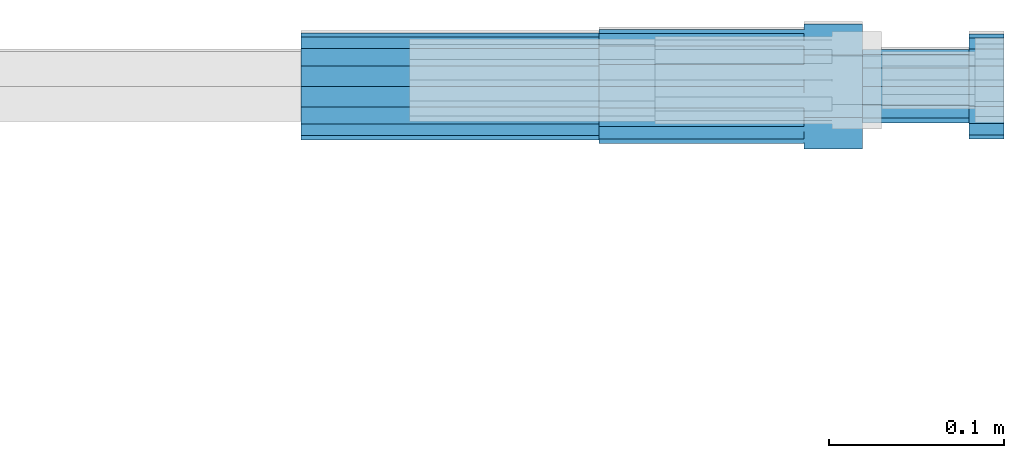
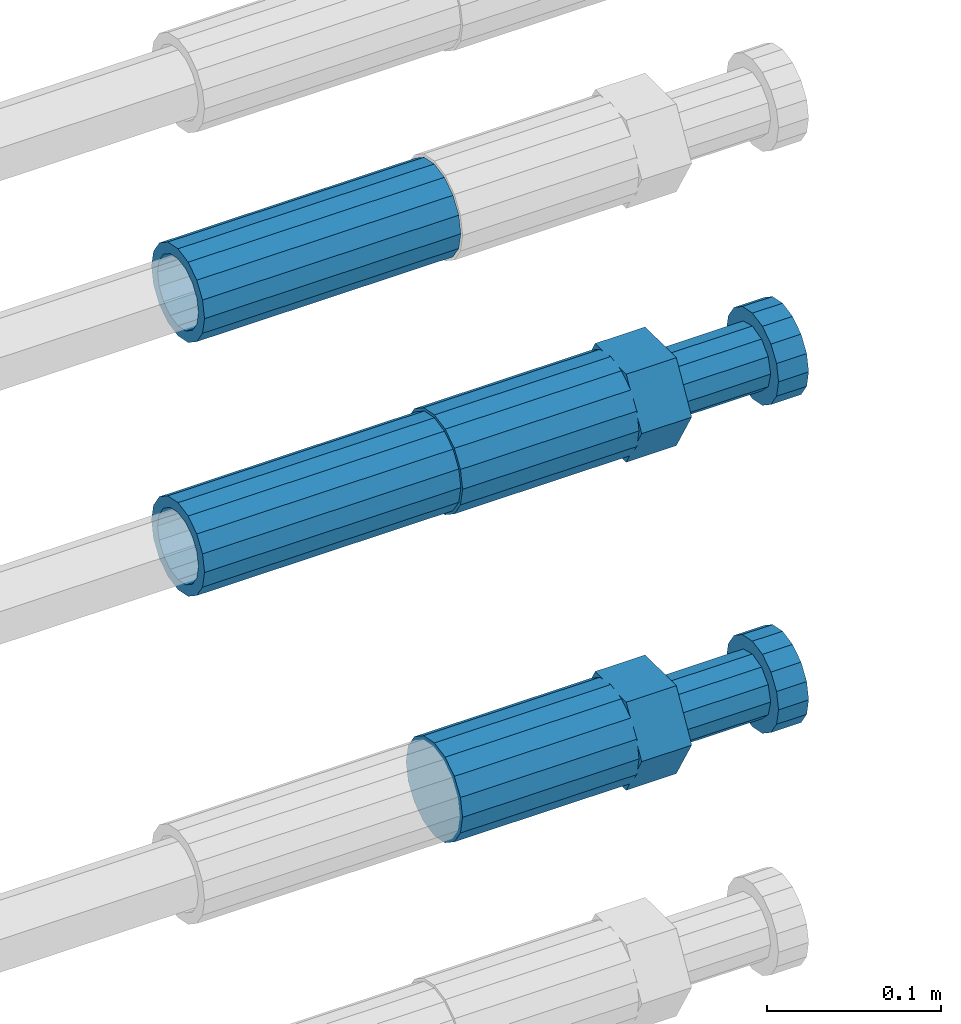
# One storey, part 117 of 119: 4 beams.
"""IFC2X3 building model written with IfcOpenShell, lengths in millimetres."""

from ifc_helpers import new_model, si_unit, frame, origin_with_axes, place, context, subcontext, project, spatial, faceted_brep, material, type_object, element, save


model = new_model("IFC2X3")

# Units and contexts
model_context = context("Model", 3, precision=1e-05, world=origin_with_axes())
body_context = subcontext(model_context, "Body", "Model", "MODEL_VIEW")
ifc_project = project(units=[si_unit("LENGTHUNIT", "METRE", prefix="MILLI"), si_unit("AREAUNIT", "SQUARE_METRE"), si_unit("VOLUMEUNIT", "CUBIC_METRE"), si_unit("MASSUNIT", "GRAM", prefix="KILO"), si_unit("TIMEUNIT", "SECOND"), si_unit("PLANEANGLEUNIT", "RADIAN"), si_unit("SOLIDANGLEUNIT", "STERADIAN"), si_unit("THERMODYNAMICTEMPERATUREUNIT", "DEGREE_CELSIUS"), si_unit("LUMINOUSINTENSITYUNIT", "LUMEN")], contexts=[model_context])

# Site, building, storey
site_placement = place(None, origin_with_axes())
site = spatial("IfcSite", under=ifc_project, at=site_placement, CompositionType="ELEMENT")
building_placement = place(site_placement, origin_with_axes())
building = spatial("IfcBuilding", under=site, at=building_placement, Name="Undefined", CompositionType="ELEMENT")
storey_placement = place(building_placement, origin_with_axes())
storey = spatial("IfcBuildingStorey", under=building, at=storey_placement, Name="Undefined", CompositionType="ELEMENT", Elevation=0.0)

# Beams
ifc_material = material(Name="STEEL/S275")
beam_type_1 = type_object("IfcBeamType", PredefinedType="NOTDEFINED")
beam_1_placement = place(storey_placement, frame((2039349.03023304, 6206399.98994599, 22034.9894122711), z_axis=(0.0, 0.0, 1.0), x_axis=(1.0, 0.0, 0.0)))
element("IfcBeam", 1, at=beam_1_placement, inside=storey, type_object=beam_type_1, material=ifc_material, Name="AG40N", context=body_context, shape_type="Brep", body=[
    faceted_brep([(1.62981450557709e-09, -23.4999999990687, 0.0), (7.45058059692383e-09, -21.7111690142192, 8.99306066057534), (170.000002125278, -21.711168999318, 8.99306066022245), (170.000002127141, -23.4999999844003, -3.66071617463604e-10), (4.65661287307739e-09, -16.6170093587134, 16.6170093578889), (170.000002122484, -16.6170093440451, 16.6170093575288), (1.86264514923096e-09, -8.99306066217832, 21.7111690140277), (170.000002118759, -8.99306064750999, 21.7111690136603), (2.3283064365387e-10, 9.31322574615479e-10, 23.5), (170.000002114102, 1.28056854009628e-08, 23.4999999996485), (-6.51925802230835e-09, 8.99306065868586, 21.7111690140241), (170.00000211224, 8.99306067335419, 21.7111690136639), (-7.45058059692383e-09, 16.6170093561523, 16.6170093578853), (170.000002109446, 16.6170093708206, 16.6170093575324), (-9.31322574615479e-09, 21.711169013055, 8.99306066057534), (170.000002108514, 21.7111690277234, 8.99306066022245), (-1.16415321826935e-09, 23.5000000009313, 0.0), (170.000002108514, 23.5000000144355, -3.66071617463604e-10), (-8.38190317153931e-09, 21.7111690151505, -8.99306066059444), (170.000002110377, 21.7111690300517, -8.9930606609546), (-5.58793544769287e-09, 16.6170093598776, -16.6170093579008), (170.000002113171, 16.6170093745459, -16.6170093582609), (-9.31322574615479e-10, 8.99306066334248, -21.7111690140396), (170.000002115965, 8.99306067801081, -21.7111690143961), (2.3283064365387e-10, 9.31322574615479e-10, -23.5), (170.00000211969, 1.7927959561348e-08, -23.5000000003843), (5.58793544769287e-09, -8.99306065752171, -21.7111690140396), (170.000002123415, -8.99306064285338, -21.7111690143961), (8.38190317153931e-09, -16.6170093549881, -16.6170093579008), (170.000002125278, -16.6170093403198, -16.6170093582646), (9.31322574615479e-09, -21.7111690121237, -8.99306066059444), (170.000002127141, -21.7111689972226, -8.9930606609546), (1.11758708953857e-08, -30.4999999990687, -9.54969436861575e-12), (1.30385160446167e-08, -28.1783257392235, -11.6718446871514), (170.000002129003, -28.1783257243223, -11.6718446875116), (170.000002129935, -30.4999999841675, -3.66071617463604e-10), (1.02445483207703e-08, -21.5667568228673, -21.5667568262129), (170.000002128072, -21.566756808199, -21.5667568265694), (7.45058059692383e-09, -11.6718446831219, -28.1783257416196), (170.000002125278, -11.6718446684536, -28.1783257419834), (3.72529029846191e-09, 3.95812094211578e-09, -30.5000000000277), (170.00000211969, 1.83936208486557e-08, -30.5000000003879), (-9.31322574615479e-10, 11.6718446905725, -28.1783257416232), (170.000002115965, 11.6718447052408, -28.1783257419797), (-6.51925802230835e-09, 21.5667568286881, -21.5667568262093), (170.000002110377, 21.5667568433564, -21.5667568265694), (-9.31322574615479e-09, 28.178325742716, -11.6718446871478), (170.000002108514, 28.1783257573843, -11.6718446875079), (-1.21071934700012e-08, 30.5, -5.91171556152403e-12), (170.000002106652, 30.5000000144355, -3.62433638656512e-10), (-1.21071934700012e-08, 28.1783257401548, 11.6718446871359), (170.00000210572, 28.1783257548232, 11.6718446867794), (-1.02445483207703e-08, 21.5667568240315, 21.5667568261974), (170.000002107583, 21.566756838467, 21.5667568258409), (-7.45058059692383e-09, 11.671844684286, 28.1783257416041), (170.000002110377, 11.6718446989544, 28.178325741244), (-2.79396772384644e-09, -2.56113708019257e-09, 30.5000000000159), (170.000002114102, 1.18743628263474e-08, 30.4999999996558), (1.86264514923096e-09, -11.6718446896411, 28.1783257416114), (170.000002118759, -11.67184467474, 28.178325741244), (7.45058059692383e-09, -21.5667568275239, 21.5667568261974), (170.000002123415, -21.5667568126228, 21.5667568258373), (1.02445483207703e-08, -28.1783257415518, 11.6718446871359), (170.000002127141, -28.1783257271163, 11.6718446867794)], [[[0, 1, 2, 3]], [[1, 4, 5, 2]], [[4, 6, 7, 5]], [[6, 8, 9, 7]], [[8, 10, 11, 9]], [[10, 12, 13, 11]], [[12, 14, 15, 13]], [[14, 16, 17, 15]], [[16, 18, 19, 17]], [[18, 20, 21, 19]], [[20, 22, 23, 21]], [[22, 24, 25, 23]], [[24, 26, 27, 25]], [[26, 28, 29, 27]], [[28, 30, 31, 29]], [[30, 0, 3, 31]], [[32, 33, 34, 35]], [[33, 36, 37, 34]], [[36, 38, 39, 37]], [[38, 40, 41, 39]], [[40, 42, 43, 41]], [[42, 44, 45, 43]], [[44, 46, 47, 45]], [[46, 48, 49, 47]], [[48, 50, 51, 49]], [[50, 52, 53, 51]], [[52, 54, 55, 53]], [[54, 56, 57, 55]], [[56, 58, 59, 57]], [[58, 60, 61, 59]], [[60, 62, 63, 61]], [[62, 32, 35, 63]], [[37, 39, 41, 43, 45, 47, 49, 51, 53, 55, 57, 59, 61, 63, 35, 34], [5, 7, 9, 11, 13, 15, 17, 19, 21, 23, 25, 27, 29, 31, 3, 2]], [[62, 60, 58, 56, 54, 52, 50, 48, 46, 44, 42, 40, 38, 36, 33, 32], [30, 28, 26, 24, 22, 20, 18, 16, 14, 12, 10, 8, 6, 4, 1, 0]]]),
])
beam_2_placement = place(storey_placement, frame((2039349.03023304, 6206399.98994599, 22212.9894122711), z_axis=(0.0, 0.0, 1.0), x_axis=(1.0, 0.0, 0.0)))
element("IfcBeam", 2, at=beam_2_placement, inside=storey, type_object=beam_type_1, material=ifc_material, Name="AG40N", context=body_context, shape_type="Brep", body=[
    faceted_brep([(1.62981450557709e-09, -23.4999999990687, 0.0), (7.45058059692383e-09, -21.7111690142192, 8.99306066057534), (170.000002125278, -21.711168999318, 8.99306066022245), (170.000002127141, -23.4999999844003, -3.66071617463604e-10), (4.65661287307739e-09, -16.6170093587134, 16.6170093578889), (170.000002122484, -16.6170093440451, 16.6170093575288), (1.86264514923096e-09, -8.99306066217832, 21.7111690140277), (170.000002118759, -8.99306064750999, 21.7111690136603), (2.3283064365387e-10, 9.31322574615479e-10, 23.5), (170.000002114102, 1.28056854009628e-08, 23.4999999996485), (-6.51925802230835e-09, 8.99306065868586, 21.7111690140241), (170.00000211224, 8.99306067335419, 21.7111690136639), (-7.45058059692383e-09, 16.6170093561523, 16.6170093578853), (170.000002109446, 16.6170093708206, 16.6170093575324), (-9.31322574615479e-09, 21.711169013055, 8.99306066057534), (170.000002108514, 21.7111690277234, 8.99306066022245), (-1.16415321826935e-09, 23.5000000009313, 0.0), (170.000002108514, 23.5000000144355, -3.66071617463604e-10), (-8.38190317153931e-09, 21.7111690151505, -8.99306066059444), (170.000002110377, 21.7111690300517, -8.9930606609546), (-5.58793544769287e-09, 16.6170093598776, -16.6170093579008), (170.000002113171, 16.6170093745459, -16.6170093582609), (-9.31322574615479e-10, 8.99306066334248, -21.7111690140396), (170.000002115965, 8.99306067801081, -21.7111690143961), (2.3283064365387e-10, 9.31322574615479e-10, -23.5), (170.00000211969, 1.7927959561348e-08, -23.5000000003843), (5.58793544769287e-09, -8.99306065752171, -21.7111690140396), (170.000002123415, -8.99306064285338, -21.7111690143961), (8.38190317153931e-09, -16.6170093549881, -16.6170093579008), (170.000002125278, -16.6170093403198, -16.6170093582646), (9.31322574615479e-09, -21.7111690121237, -8.99306066059444), (170.000002127141, -21.7111689972226, -8.9930606609546), (1.11758708953857e-08, -30.4999999990687, -9.54969436861575e-12), (1.30385160446167e-08, -28.1783257392235, -11.6718446871514), (170.000002129003, -28.1783257243223, -11.6718446875116), (170.000002129935, -30.4999999841675, -3.66071617463604e-10), (1.02445483207703e-08, -21.5667568228673, -21.5667568262129), (170.000002128072, -21.566756808199, -21.5667568265694), (7.45058059692383e-09, -11.6718446831219, -28.1783257416196), (170.000002125278, -11.6718446684536, -28.1783257419834), (3.72529029846191e-09, 3.95812094211578e-09, -30.5000000000277), (170.00000211969, 1.83936208486557e-08, -30.5000000003879), (-9.31322574615479e-10, 11.6718446905725, -28.1783257416232), (170.000002115965, 11.6718447052408, -28.1783257419797), (-6.51925802230835e-09, 21.5667568286881, -21.5667568262093), (170.000002110377, 21.5667568433564, -21.5667568265694), (-9.31322574615479e-09, 28.178325742716, -11.6718446871478), (170.000002108514, 28.1783257573843, -11.6718446875079), (-1.21071934700012e-08, 30.5, -5.91171556152403e-12), (170.000002106652, 30.5000000144355, -3.62433638656512e-10), (-1.21071934700012e-08, 28.1783257401548, 11.6718446871359), (170.00000210572, 28.1783257548232, 11.6718446867794), (-1.02445483207703e-08, 21.5667568240315, 21.5667568261974), (170.000002107583, 21.566756838467, 21.5667568258409), (-7.45058059692383e-09, 11.671844684286, 28.1783257416041), (170.000002110377, 11.6718446989544, 28.178325741244), (-2.79396772384644e-09, -2.56113708019257e-09, 30.5000000000159), (170.000002114102, 1.18743628263474e-08, 30.4999999996558), (1.86264514923096e-09, -11.6718446896411, 28.1783257416114), (170.000002118759, -11.67184467474, 28.178325741244), (7.45058059692383e-09, -21.5667568275239, 21.5667568261974), (170.000002123415, -21.5667568126228, 21.5667568258373), (1.02445483207703e-08, -28.1783257415518, 11.6718446871359), (170.000002127141, -28.1783257271163, 11.6718446867794)], [[[0, 1, 2, 3]], [[1, 4, 5, 2]], [[4, 6, 7, 5]], [[6, 8, 9, 7]], [[8, 10, 11, 9]], [[10, 12, 13, 11]], [[12, 14, 15, 13]], [[14, 16, 17, 15]], [[16, 18, 19, 17]], [[18, 20, 21, 19]], [[20, 22, 23, 21]], [[22, 24, 25, 23]], [[24, 26, 27, 25]], [[26, 28, 29, 27]], [[28, 30, 31, 29]], [[30, 0, 3, 31]], [[32, 33, 34, 35]], [[33, 36, 37, 34]], [[36, 38, 39, 37]], [[38, 40, 41, 39]], [[40, 42, 43, 41]], [[42, 44, 45, 43]], [[44, 46, 47, 45]], [[46, 48, 49, 47]], [[48, 50, 51, 49]], [[50, 52, 53, 51]], [[52, 54, 55, 53]], [[54, 56, 57, 55]], [[56, 58, 59, 57]], [[58, 60, 61, 59]], [[60, 62, 63, 61]], [[62, 32, 35, 63]], [[37, 39, 41, 43, 45, 47, 49, 51, 53, 55, 57, 59, 61, 63, 35, 34], [5, 7, 9, 11, 13, 15, 17, 19, 21, 23, 25, 27, 29, 31, 3, 2]], [[62, 60, 58, 56, 54, 52, 50, 48, 46, 44, 42, 40, 38, 36, 33, 32], [30, 28, 26, 24, 22, 20, 18, 16, 14, 12, 10, 8, 6, 4, 1, 0]]]),
])
beam_type_2 = type_object("IfcBeamType", Name="ROD65", PredefinedType="NOTDEFINED")
beam_3_placement = place(storey_placement, frame((2039519.03023304, 6206399.98994599, 21804.9894143674), z_axis=(0.0, 0.0, 1.0), x_axis=(1.0, 0.0, 0.0)))
element("IfcBeam", 3, at=beam_3_placement, inside=storey, type_object=beam_type_2, material=ifc_material, Name="AGB40", ObjectType="ROD65", context=body_context, shape_type="Brep", body=[
    faceted_brep([(116.999999999069, 17.8249999252148, 30.8738056446964), (116.999999998137, 22.0056957420893, 23.632628078838), (116.999999999069, 12.4372115600854, 30.0260848066173), (116.999999999069, 8.17543111252598, 30.8738056446964), (117.000000000931, -17.8250000746921, 30.8738056446964), (150.200000001118, -17.8250000723638, 30.8738056446964), (150.199999999255, 17.8249999275431, 30.8738056446964), (117.000000000931, -8.17543109622784, 30.8738056446964), (117.000000001863, -22.0056959956419, 23.6326278985034), (117.000000000931, -12.4372115437873, 30.0260848066173), (117.000000001863, -35.6500000746455, -2.18278728425503e-10), (150.200000002049, -35.6500000723172, -2.18278728425503e-10), (117.000000001863, -30.8443149488885, 8.32369080289209), (117.000000001863, -30.8443149488885, -8.32369080355784), (117.000000002794, -32.4999999918509, 0.0), (117.000000000931, -17.8250000746921, -30.873805645133), (150.200000001118, -17.8250000723638, -30.873805645133), (117.000000001863, -22.0056959961075, -23.6326278982269), (117.000000000931, -8.17543109389953, -30.873805645133), (117.000000000931, -12.4372115437873, -30.0260848066173), (116.999999999069, 17.8249999252148, -30.873805645133), (150.199999999255, 17.8249999275431, -30.873805645133), (116.999999999069, 8.17543111019768, -30.873805645133), (116.999999999069, 12.4372115600854, -30.0260848066173), (116.999999998137, 22.005695742555, -23.6326280785652), (116.999999998137, 35.6499999251682, -2.18278728425503e-10), (150.199999998324, 35.6499999277294, -2.18278728425503e-10), (116.999999998137, 30.8443150522653, -8.32369036550881), (116.999999997206, 32.5000000081491, 0.0), (116.999999998137, 30.8443150522653, 8.32369036483942), (1.86264514923096e-09, -22.9809703885112, 22.9809703885621), (1.86264514923096e-09, -30.0260848065373, 12.4372115518672), (117.000000001863, -30.0260847983882, 12.4372115518672), (117.000000001863, -22.9809703803621, 22.9809703885621), (-1.86264514923096e-09, 22.9809703885112, -22.9809703885621), (-1.86264514923096e-09, 30.0260848065373, -12.4372115518672), (116.999999998137, 30.0260848146863, -12.4372115518672), (116.999999998137, 22.9809703966603, -22.9809703885621), (1.86264514923096e-09, -30.0260848065373, -12.4372115518672), (1.86264514923096e-09, -22.9809703885112, -22.9809703885621), (117.000000001863, -22.9809703803621, -22.9809703885621), (117.000000001863, -30.0260847983882, -12.4372115518672), (9.31322574615479e-10, -12.4372115519363, 30.0260848066173), (0.0, 0.0, 32.5), (-9.31322574615479e-10, 12.4372115519363, 30.0260848066173), (-1.86264514923096e-09, 22.9809703885112, 22.9809703885621), (-1.86264514923096e-09, 30.0260848065373, 12.4372115518672), (-2.79396772384644e-09, 32.5, 0.0), (-9.31322574615479e-10, 12.4372115519363, -30.0260848066173), (0.0, 0.0, -32.5), (9.31322574615479e-10, -12.4372115519363, -30.0260848066173), (2.79396772384644e-09, -32.5, 0.0), (116.999999998137, 22.9809703966603, 22.9809703885621), (116.999999998137, 30.0260848146863, 12.4372115518672), (117.0, 8.14907252788544e-09, -32.5), (117.0, 8.14907252788544e-09, 32.5), (150.200000000186, -10.5000000959262, 18.1865334791873), (150.199999999255, -9.59262251853943e-08, 20.9999999997126), (150.199999998324, 10.4999999040738, 18.1865334791873), (150.199999997392, 18.1865333835594, 10.4999999997126), (150.199999997392, 20.9999999040738, -2.87400325760245e-10), (150.199999997392, 18.1865333835594, -10.5000000002874), (150.199999998324, 10.4999999040738, -18.1865334797621), (150.199999999255, -9.59262251853943e-08, -21.0000000002874), (150.200000000186, -10.5000000959262, -18.1865334797621), (150.200000000186, -18.1865335754119, -10.5000000002874), (150.200000001118, -21.0000000959262, -2.87400325760245e-10), (150.200000000186, -18.1865335754119, 10.4999999997126), (210.979999999516, 10.4999999082647, 18.1865334791873), (210.979999999516, -9.17352735996246e-08, 20.9999999997126), (210.979999997653, 18.1865333877504, 10.4999999997126), (210.979999997653, 20.9999999082647, -2.87400325760245e-10), (210.979999997653, 18.1865333877504, -10.5000000002874), (210.979999999516, 10.4999999082647, -18.1865334797621), (210.979999999516, -9.17352735996246e-08, -21.0000000002874), (210.979999999516, -10.5000000917353, -18.1865334797621), (210.980000000447, -18.1865335712209, -10.5000000002874), (210.980000001378, -21.0000000917353, -2.87400325760245e-10), (210.980000000447, -18.1865335712209, 10.4999999997126), (210.979999999516, -10.5000000917353, 18.1865334791873), (211.001368402503, -27.7269939335529, -11.4911163272045), (211.003082515672, -21.2238095656503, -21.2238154190527), (231.002518340945, -21.2131946226582, -21.2132004554769), (231.000804228708, -27.7163789905608, -11.4805013636287), (211.001368415542, -11.4911086384673, -27.7269970399575), (231.000804241747, -11.4804936954752, -27.7163820763781), (210.996487061493, -0.0106066407170147, -30.0106107396168), (230.995922887698, 8.30227509140968e-06, -29.999995776041), (210.98918159306, 11.4698940692469, -27.7269970332745), (230.988617419265, 11.4805090120062, -27.7163820696951), (210.980564201251, 21.2025913291145, -21.2238154067054), (230.980000027455, 21.2132062721066, -21.2132004431296), (210.971946807578, 27.7057702087332, -11.4911163110701), (230.971382633783, 27.7163851517253, -11.4805013474943), (210.964641331695, 29.9893806746695, -0.0106149565435771), (230.9640771579, 29.9999956176616, 7.03221303410828e-09), (210.959759964608, 27.7057637346443, 11.4698863966551), (230.959195790812, 27.7163786776364, 11.4805013602345), (210.958045851439, 21.2025793667417, 21.2025854885032), (230.957481677644, 21.2131943097338, 21.2132004520827), (210.959759951569, 11.4698784395587, 27.705767109408), (230.959195776843, 11.4804933823179, 27.7163820729838), (210.964641305618, -0.0106235581915826, 29.9893808090674), (230.964077131823, -8.61519947648048e-06, 29.9999957726432), (210.971946774051, -11.4911242681555, 27.7057671027251), (230.971382599324, -11.4805093251634, 27.7163820663009), (210.98056416586, -21.2238215280231, 21.2025854761559), (230.979999991134, -21.2132065852638, 21.2132004397354), (210.989181559533, -27.7270004076418, 11.4698863805206), (230.988617384806, -27.7163854646496, 11.4805013441), (210.996487035416, -30.0106108735781, -0.0106149740058754), (230.995922861621, -29.999995930586, -1.04300852399319e-08)], [[[0, 1, 2, 3]], [[4, 5, 6, 0, 3, 7]], [[8, 4, 7, 9]], [[10, 11, 5, 4, 8, 12]], [[13, 10, 12, 14]], [[15, 16, 11, 10, 13, 17]], [[18, 15, 17, 19]], [[20, 21, 16, 15, 18, 22]], [[20, 22, 23, 24]], [[25, 26, 21, 20, 24, 27]], [[25, 27, 28, 29]], [[30, 31, 32, 33]], [[34, 35, 36, 37]], [[38, 39, 40, 41]], [[31, 30, 42, 43, 44, 45, 46, 47, 35, 34, 48, 49, 50, 39, 38, 51]], [[46, 45, 52, 53]], [[28, 47, 46, 53, 29]], [[27, 36, 35, 47, 28]], [[24, 37, 36, 27]], [[23, 48, 34, 37, 24]], [[22, 54, 49, 48, 23]], [[18, 54, 22]], [[19, 50, 49, 54, 18]], [[17, 40, 39, 50, 19]], [[13, 41, 40, 17]], [[14, 51, 38, 41, 13]], [[12, 32, 31, 51, 14]], [[8, 33, 32, 12]], [[9, 42, 30, 33, 8]], [[7, 55, 43, 42, 9]], [[3, 55, 7]], [[2, 44, 43, 55, 3]], [[1, 52, 45, 44, 2]], [[29, 53, 52, 1]], [[0, 6, 26, 25, 29, 1]], [[5, 11, 16, 21, 26, 6], [56, 57, 58, 59, 60, 61, 62, 63, 64, 65, 66, 67]], [[68, 58, 57, 69]], [[70, 59, 58, 68]], [[71, 60, 59, 70]], [[72, 61, 60, 71]], [[73, 62, 61, 72]], [[74, 63, 62, 73]], [[75, 64, 63, 74]], [[76, 65, 64, 75]], [[77, 66, 65, 76]], [[78, 67, 66, 77]], [[79, 56, 67, 78]], [[69, 57, 56, 79]], [[80, 81, 82, 83]], [[81, 84, 85, 82]], [[84, 86, 87, 85]], [[86, 88, 89, 87]], [[88, 90, 91, 89]], [[90, 92, 93, 91]], [[92, 94, 95, 93]], [[94, 96, 97, 95]], [[96, 98, 99, 97]], [[98, 100, 101, 99]], [[100, 102, 103, 101]], [[102, 104, 105, 103]], [[104, 106, 107, 105]], [[106, 108, 109, 107]], [[108, 110, 111, 109]], [[82, 85, 87, 89, 91, 93, 95, 97, 99, 101, 103, 105, 107, 109, 111, 83]], [[110, 80, 83, 111]], [[108, 106, 104, 102, 100, 98, 96, 94, 92, 90, 88, 86, 84, 81, 80, 110], [78, 77, 76, 75, 74, 73, 72, 71, 70, 68, 69, 79]]]),
])
beam_4_placement = place(storey_placement, frame((2039519.03023304, 6206399.98994599, 22034.9894143674), z_axis=(0.0, 0.0, 1.0), x_axis=(1.0, 0.0, 0.0)))
element("IfcBeam", 4, at=beam_4_placement, inside=storey, type_object=beam_type_2, material=ifc_material, Name="AGB40", ObjectType="ROD65", context=body_context, shape_type="Brep", body=[
    faceted_brep([(116.999999999069, 17.8249999252148, 30.8738056446964), (116.999999998137, 22.0056957420893, 23.632628078838), (116.999999999069, 12.4372115600854, 30.0260848066173), (116.999999999069, 8.17543111252598, 30.8738056446964), (117.000000000931, -17.8250000746921, 30.8738056446964), (150.200000001118, -17.8250000723638, 30.8738056446964), (150.199999999255, 17.8249999275431, 30.8738056446964), (117.000000000931, -8.17543109622784, 30.8738056446964), (117.000000001863, -22.0056959956419, 23.6326278985034), (117.000000000931, -12.4372115437873, 30.0260848066173), (117.000000001863, -35.6500000746455, -2.18278728425503e-10), (150.200000002049, -35.6500000723172, -2.18278728425503e-10), (117.000000001863, -30.8443149488885, 8.32369080289209), (117.000000001863, -30.8443149488885, -8.32369080355784), (117.000000002794, -32.4999999918509, 0.0), (117.000000000931, -17.8250000746921, -30.873805645133), (150.200000001118, -17.8250000723638, -30.873805645133), (117.000000001863, -22.0056959961075, -23.6326278982269), (117.000000000931, -8.17543109389953, -30.873805645133), (117.000000000931, -12.4372115437873, -30.0260848066173), (116.999999999069, 17.8249999252148, -30.873805645133), (150.199999999255, 17.8249999275431, -30.873805645133), (116.999999999069, 8.17543111019768, -30.873805645133), (116.999999999069, 12.4372115600854, -30.0260848066173), (116.999999998137, 22.005695742555, -23.6326280785652), (116.999999998137, 35.6499999251682, -2.18278728425503e-10), (150.199999998324, 35.6499999277294, -2.18278728425503e-10), (116.999999998137, 30.8443150522653, -8.32369036550881), (116.999999997206, 32.5000000081491, 0.0), (116.999999998137, 30.8443150522653, 8.32369036483942), (1.86264514923096e-09, -22.9809703885112, 22.9809703885621), (1.86264514923096e-09, -30.0260848065373, 12.4372115518672), (117.000000001863, -30.0260847983882, 12.4372115518672), (117.000000001863, -22.9809703803621, 22.9809703885621), (-1.86264514923096e-09, 22.9809703885112, -22.9809703885621), (-1.86264514923096e-09, 30.0260848065373, -12.4372115518672), (116.999999998137, 30.0260848146863, -12.4372115518672), (116.999999998137, 22.9809703966603, -22.9809703885621), (1.86264514923096e-09, -30.0260848065373, -12.4372115518672), (1.86264514923096e-09, -22.9809703885112, -22.9809703885621), (117.000000001863, -22.9809703803621, -22.9809703885621), (117.000000001863, -30.0260847983882, -12.4372115518672), (9.31322574615479e-10, -12.4372115519363, 30.0260848066173), (0.0, 0.0, 32.5), (-9.31322574615479e-10, 12.4372115519363, 30.0260848066173), (-1.86264514923096e-09, 22.9809703885112, 22.9809703885621), (-1.86264514923096e-09, 30.0260848065373, 12.4372115518672), (-2.79396772384644e-09, 32.5, 0.0), (-9.31322574615479e-10, 12.4372115519363, -30.0260848066173), (0.0, 0.0, -32.5), (9.31322574615479e-10, -12.4372115519363, -30.0260848066173), (2.79396772384644e-09, -32.5, 0.0), (116.999999998137, 22.9809703966603, 22.9809703885621), (116.999999998137, 30.0260848146863, 12.4372115518672), (117.0, 8.14907252788544e-09, -32.5), (117.0, 8.14907252788544e-09, 32.5), (150.200000000186, -10.5000000959262, 18.1865334791873), (150.199999999255, -9.59262251853943e-08, 20.9999999997126), (150.199999998324, 10.4999999040738, 18.1865334791873), (150.199999997392, 18.1865333835594, 10.4999999997126), (150.199999997392, 20.9999999040738, -2.87400325760245e-10), (150.199999997392, 18.1865333835594, -10.5000000002874), (150.199999998324, 10.4999999040738, -18.1865334797621), (150.199999999255, -9.59262251853943e-08, -21.0000000002874), (150.200000000186, -10.5000000959262, -18.1865334797621), (150.200000000186, -18.1865335754119, -10.5000000002874), (150.200000001118, -21.0000000959262, -2.87400325760245e-10), (150.200000000186, -18.1865335754119, 10.4999999997126), (210.979999999516, 10.4999999082647, 18.1865334791873), (210.979999999516, -9.17352735996246e-08, 20.9999999997126), (210.979999997653, 18.1865333877504, 10.4999999997126), (210.979999997653, 20.9999999082647, -2.87400325760245e-10), (210.979999997653, 18.1865333877504, -10.5000000002874), (210.979999999516, 10.4999999082647, -18.1865334797621), (210.979999999516, -9.17352735996246e-08, -21.0000000002874), (210.979999999516, -10.5000000917353, -18.1865334797621), (210.980000000447, -18.1865335712209, -10.5000000002874), (210.980000001378, -21.0000000917353, -2.87400325760245e-10), (210.980000000447, -18.1865335712209, 10.4999999997126), (210.979999999516, -10.5000000917353, 18.1865334791873), (211.001368402503, -27.7269939335529, -11.4911163272045), (211.003082515672, -21.2238095656503, -21.2238154190527), (231.002518340945, -21.2131946226582, -21.2132004554769), (231.000804228708, -27.7163789905608, -11.4805013636287), (211.001368415542, -11.4911086384673, -27.7269970399575), (231.000804241747, -11.4804936954752, -27.7163820763781), (210.996487061493, -0.0106066407170147, -30.0106107396168), (230.995922887698, 8.30227509140968e-06, -29.999995776041), (210.98918159306, 11.4698940692469, -27.7269970332745), (230.988617419265, 11.4805090120062, -27.7163820696951), (210.980564201251, 21.2025913291145, -21.2238154067054), (230.980000027455, 21.2132062721066, -21.2132004431296), (210.971946807578, 27.7057702087332, -11.4911163110701), (230.971382633783, 27.7163851517253, -11.4805013474943), (210.964641331695, 29.9893806746695, -0.0106149565435771), (230.9640771579, 29.9999956176616, 7.03221303410828e-09), (210.959759964608, 27.7057637346443, 11.4698863966551), (230.959195790812, 27.7163786776364, 11.4805013602345), (210.958045851439, 21.2025793667417, 21.2025854885032), (230.957481677644, 21.2131943097338, 21.2132004520827), (210.959759951569, 11.4698784395587, 27.705767109408), (230.959195776843, 11.4804933823179, 27.7163820729838), (210.964641305618, -0.0106235581915826, 29.9893808090674), (230.964077131823, -8.61519947648048e-06, 29.9999957726432), (210.971946774051, -11.4911242681555, 27.7057671027251), (230.971382599324, -11.4805093251634, 27.7163820663009), (210.98056416586, -21.2238215280231, 21.2025854761559), (230.979999991134, -21.2132065852638, 21.2132004397354), (210.989181559533, -27.7270004076418, 11.4698863805206), (230.988617384806, -27.7163854646496, 11.4805013441), (210.996487035416, -30.0106108735781, -0.0106149740058754), (230.995922861621, -29.999995930586, -1.04300852399319e-08)], [[[0, 1, 2, 3]], [[4, 5, 6, 0, 3, 7]], [[8, 4, 7, 9]], [[10, 11, 5, 4, 8, 12]], [[13, 10, 12, 14]], [[15, 16, 11, 10, 13, 17]], [[18, 15, 17, 19]], [[20, 21, 16, 15, 18, 22]], [[20, 22, 23, 24]], [[25, 26, 21, 20, 24, 27]], [[25, 27, 28, 29]], [[30, 31, 32, 33]], [[34, 35, 36, 37]], [[38, 39, 40, 41]], [[31, 30, 42, 43, 44, 45, 46, 47, 35, 34, 48, 49, 50, 39, 38, 51]], [[46, 45, 52, 53]], [[28, 47, 46, 53, 29]], [[27, 36, 35, 47, 28]], [[24, 37, 36, 27]], [[23, 48, 34, 37, 24]], [[22, 54, 49, 48, 23]], [[18, 54, 22]], [[19, 50, 49, 54, 18]], [[17, 40, 39, 50, 19]], [[13, 41, 40, 17]], [[14, 51, 38, 41, 13]], [[12, 32, 31, 51, 14]], [[8, 33, 32, 12]], [[9, 42, 30, 33, 8]], [[7, 55, 43, 42, 9]], [[3, 55, 7]], [[2, 44, 43, 55, 3]], [[1, 52, 45, 44, 2]], [[29, 53, 52, 1]], [[0, 6, 26, 25, 29, 1]], [[5, 11, 16, 21, 26, 6], [56, 57, 58, 59, 60, 61, 62, 63, 64, 65, 66, 67]], [[68, 58, 57, 69]], [[70, 59, 58, 68]], [[71, 60, 59, 70]], [[72, 61, 60, 71]], [[73, 62, 61, 72]], [[74, 63, 62, 73]], [[75, 64, 63, 74]], [[76, 65, 64, 75]], [[77, 66, 65, 76]], [[78, 67, 66, 77]], [[79, 56, 67, 78]], [[69, 57, 56, 79]], [[80, 81, 82, 83]], [[81, 84, 85, 82]], [[84, 86, 87, 85]], [[86, 88, 89, 87]], [[88, 90, 91, 89]], [[90, 92, 93, 91]], [[92, 94, 95, 93]], [[94, 96, 97, 95]], [[96, 98, 99, 97]], [[98, 100, 101, 99]], [[100, 102, 103, 101]], [[102, 104, 105, 103]], [[104, 106, 107, 105]], [[106, 108, 109, 107]], [[108, 110, 111, 109]], [[82, 85, 87, 89, 91, 93, 95, 97, 99, 101, 103, 105, 107, 109, 111, 83]], [[110, 80, 83, 111]], [[108, 106, 104, 102, 100, 98, 96, 94, 92, 90, 88, 86, 84, 81, 80, 110], [78, 77, 76, 75, 74, 73, 72, 71, 70, 68, 69, 79]]]),
])

save(model, "model.ifc")
